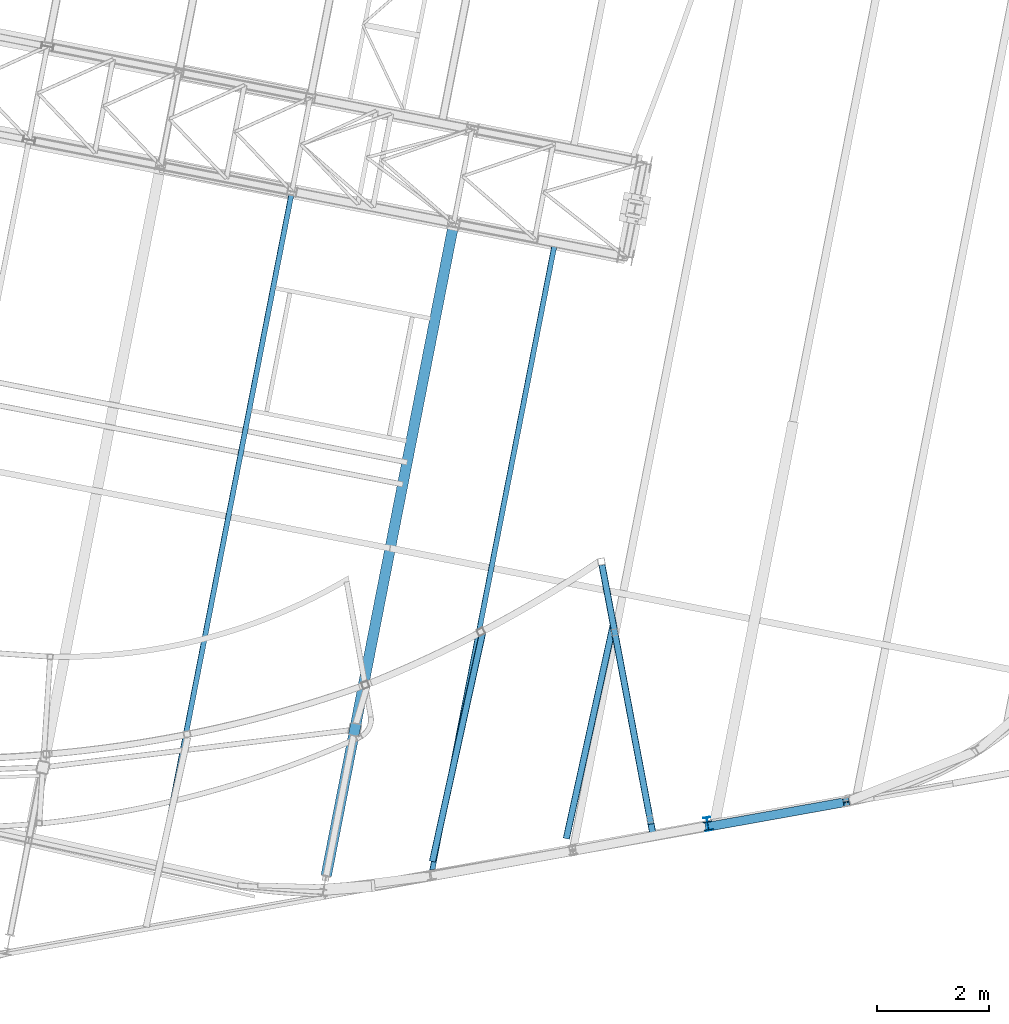
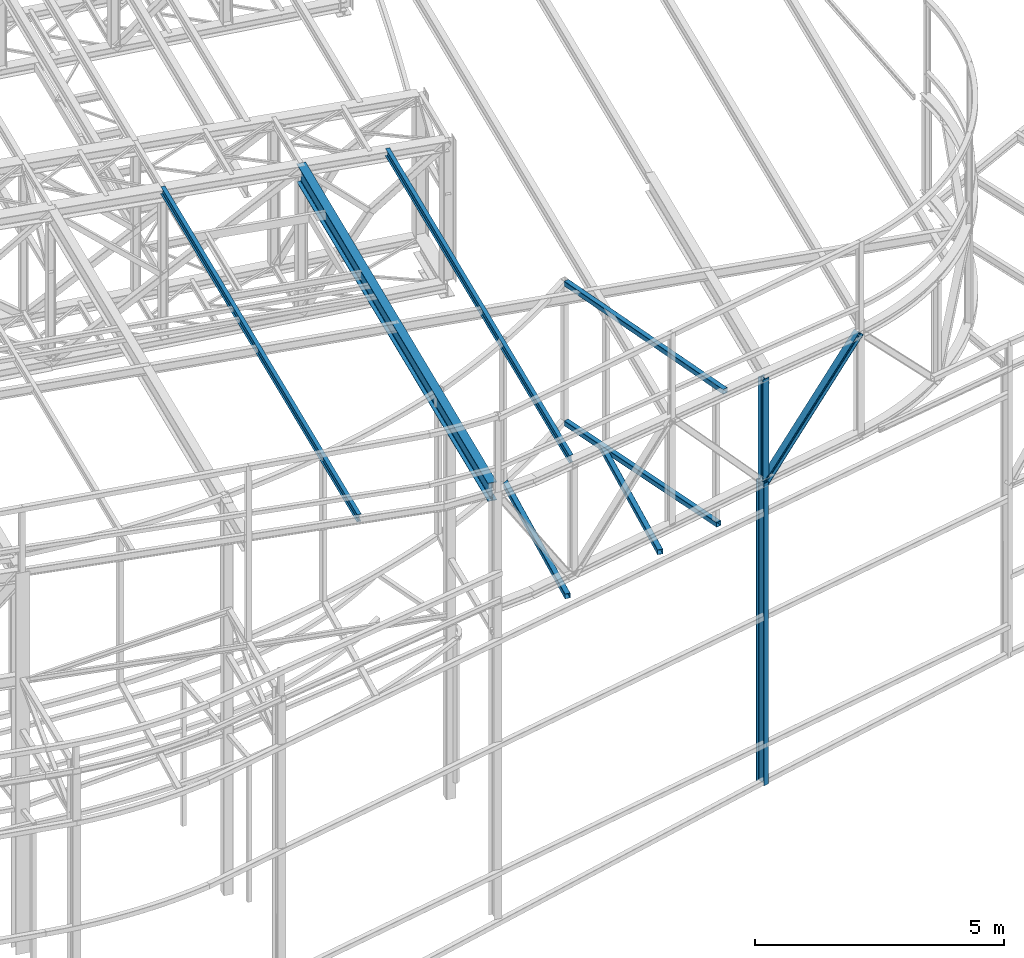
# One storey, part 57 of 215: 9 beams, 1 member, 10 elements without a shape of their own.
"""IFC2X3 building model written with IfcOpenShell, lengths in millimetres."""

from ifc_helpers import new_model, si_unit, frame, origin_with_axes, origin_2d_with_axis, place, context, subcontext, project, spatial, hollow_rectangle, i_section, extrude, clip, halfspace, material, type_object, element, aggregate, save


model = new_model("IFC2X3")

# Units and contexts
model_context = context("Model", 3, precision=1e-05, world=origin_with_axes())
body_context = subcontext(model_context, "Body", "Model", "MODEL_VIEW")
ifc_project = project(units=[si_unit("LENGTHUNIT", "METRE", prefix="MILLI"), si_unit("AREAUNIT", "SQUARE_METRE"), si_unit("VOLUMEUNIT", "CUBIC_METRE"), si_unit("MASSUNIT", "GRAM", prefix="KILO"), si_unit("TIMEUNIT", "SECOND"), si_unit("PLANEANGLEUNIT", "RADIAN"), si_unit("SOLIDANGLEUNIT", "STERADIAN"), si_unit("THERMODYNAMICTEMPERATUREUNIT", "DEGREE_CELSIUS"), si_unit("LUMINOUSINTENSITYUNIT", "LUMEN")], contexts=[model_context])

# Site, building, storey
site_placement = place(None, origin_with_axes())
site = spatial("IfcSite", under=ifc_project, at=site_placement, CompositionType="ELEMENT")
building_placement = place(site_placement, origin_with_axes())
building = spatial("IfcBuilding", under=site, at=building_placement, Name="Undefined", CompositionType="ELEMENT")
storey_placement = place(building_placement, origin_with_axes())
storey = spatial("IfcBuildingStorey", under=building, at=storey_placement, Name="Undefined", CompositionType="ELEMENT", Elevation=0.0)

# Assembly, beam
assembly_1_placement = place(storey_placement, origin_with_axes())
assembly_1 = element("IfcElementAssembly", 1, at=assembly_1_placement, inside=storey, Name="Steel Assembly", AssemblyPlace="NOTDEFINED", PredefinedType="RIGID_FRAME")
ifc_material = material(Name="STEEL/S275JR")
beam_type_1 = type_object("IfcBeamType", Name="IPE240", PredefinedType="NOTDEFINED")
beam_1_placement = place(assembly_1_placement, frame((91016.7687788865, 2951.99968971468, 9426.73715546441), z_axis=(-0.1771386489551, 0.98418590675053, -1.00000033828228e-09), x_axis=(0.0, 0.0, -1.0)))
beam_1 = element("IfcBeam", 2, at=beam_1_placement, type_object=beam_type_1, material=ifc_material, Name="MONTANT", ObjectType="IPE240", context=body_context, shape_type="Clipping", body=[
    clip(extrude(i_section(OverallWidth=120.0, OverallDepth=240.0, WebThickness=6.199999809, FlangeThickness=9.800000191, FilletRadius=15.0, at=origin_2d_with_axis()), frame((7423.4693885648, -1.45519152283669e-11, 0.0), z_axis=(-1.0, 0.0, 0.0), x_axis=(-6.93889390390723e-18, -1.0, -3.46944695195361e-18)), (0.0, 0.0, 1.0), 7423.5), halfspace(frame((7427.22859070963, 144.732145965143, -109.878690185373), z_axis=(-0.999000439160357, 0.0447003583089576, 2.29011865297713e-05), x_axis=(-1.00009037889739e-09, -0.000512348971731184, 0.999999868749257)), True)),
])
aggregate(assembly_1, [beam_1])

assembly_2_placement = place(storey_placement, origin_with_axes())
assembly_2 = element("IfcElementAssembly", 3, at=assembly_2_placement, inside=storey, Name="Steel Assembly", AssemblyPlace="NOTDEFINED", PredefinedType="RIGID_FRAME")
beam_type_2 = type_object("IfcBeamType", PredefinedType="NOTDEFINED")
beam_2_placement = place(assembly_2_placement, frame((89242.2107585349, 6095.02559260386, 8706.00013875785), z_axis=(0.976715475916409, -0.21453875898164, -1.00000033845017e-09), x_axis=(-0.214538758981639, -0.97671547591641, 0.0)))
beam_2 = element("IfcBeam", 4, at=beam_2_placement, type_object=beam_type_2, material=ifc_material, Name="LISSE", context=body_context, shape_type="Clipping", body=[
    clip(extrude(hollow_rectangle(XDim=120.0, YDim=120.0, WallThickness=5.0, InnerFilletRadius=5.0, OuterFilletRadius=10.0, at=origin_2d_with_axis()), frame((3486.87129744093, 1.81898940354586e-12, 9.67801199580878e-14), z_axis=(-1.0, 0.0, 0.0), x_axis=(-6.93889390390723e-18, -1.0, -3.46944695195361e-18)), (0.0, 0.0, 1.0), 3932.2), halfspace(frame((-226.451803865377, -59.999922311963, 16.6979386273451), z_axis=(0.392506577380147, -6.14406825347277e-09, -0.919749197723664), x_axis=(-6.93889390390723e-18, -1.0, -3.46944695195361e-18)), True)),
])
aggregate(assembly_2, [beam_2])

assembly_3_placement = place(storey_placement, origin_with_axes())
assembly_3 = element("IfcElementAssembly", 5, at=assembly_3_placement, inside=storey, Name="Steel Assembly", AssemblyPlace="NOTDEFINED", PredefinedType="RIGID_FRAME")
beam_3_placement = place(assembly_3_placement, frame((86972.7295310534, 6219.98047719203, 8706.00014167623), z_axis=(0.976715475916409, -0.21453875898164, -1.00000033845017e-09), x_axis=(-0.214538758981639, -0.97671547591641, 0.0)))
beam_3 = element("IfcBeam", 6, at=beam_3_placement, type_object=beam_type_2, material=ifc_material, Name="LISSE", context=body_context, shape_type="Clipping", body=[
    clip(extrude(hollow_rectangle(XDim=120.0, YDim=120.0, WallThickness=5.0, InnerFilletRadius=5.0, OuterFilletRadius=10.0, at=origin_2d_with_axis()), frame((4032.18191022412, 1.04229459450763e-22, 0.0), z_axis=(-1.0, 0.0, 0.0), x_axis=(-6.93889390390723e-18, -1.0, -3.46944695195361e-18)), (0.0, 0.0, 1.0), 4210.9), halfspace(frame((-145.120148966242, -59.9999350530652, 50.6813305532123), z_axis=(-0.771983742847682, -1.66052058476079e-09, -0.635642274222604), x_axis=(-6.93889390390723e-18, -1.0, -3.46944695195361e-18)), False)),
])
aggregate(assembly_3, [beam_3])

assembly_4_placement = place(storey_placement, origin_with_axes())
assembly_4 = element("IfcElementAssembly", 7, at=assembly_4_placement, inside=storey, Name="Steel Assembly", AssemblyPlace="NOTDEFINED", PredefinedType="RIGID_FRAME")
beam_4_placement = place(assembly_4_placement, frame((90005.0818830192, 2949.28661403261, 8706.00036403863), z_axis=(0.0, 0.0, -1.0), x_axis=(-0.186031417077286, 0.982543796408188, 3.29999998263352e-08)))
beam_4 = element("IfcBeam", 8, at=beam_4_placement, type_object=beam_type_2, material=ifc_material, Name="LISSE", context=body_context, shape_type="Clipping", body=[
    clip(extrude(hollow_rectangle(XDim=120.0, YDim=120.0, WallThickness=5.0, InnerFilletRadius=5.0, OuterFilletRadius=10.0, at=origin_2d_with_axis()), frame((4744.91866222964, -4.3446607691232e-14, -1.81898940354586e-12), z_axis=(-1.0, 0.0, 0.0), x_axis=(-6.93889390390723e-18, -1.0, -3.46944695195361e-18)), (0.0, 0.0, 1.0), 4744.9), halfspace(frame((4700.91971664662, 47.4391541010264, -59.9995418697345), z_axis=(-0.999410911530851, -0.0343195267023399, -3.25403953064898e-08), x_axis=(0.0, 0.0, -1.0)), True)),
])
aggregate(assembly_4, [beam_4])

assembly_5_placement = place(storey_placement, origin_with_axes())
assembly_5 = element("IfcElementAssembly", 9, at=assembly_5_placement, inside=storey, Name="Steel Assembly", AssemblyPlace="NOTDEFINED", PredefinedType="RIGID_FRAME")
beam_5_placement = place(assembly_5_placement, frame((90042.1218101927, 2753.50984265894, 12075.3447147273), z_axis=(-0.00277681399979952, 0.0119642699991486, -0.999924569928851), x_axis=(-0.186031387047881, 0.982467160252867, 0.0122720030031586)))
beam_5 = element("IfcBeam", 10, at=beam_5_placement, type_object=beam_type_2, material=ifc_material, Name="LISSE", context=body_context, shape_type="Clipping", body=[
    clip(extrude(hollow_rectangle(XDim=120.0, YDim=120.0, WallThickness=5.0, InnerFilletRadius=5.0, OuterFilletRadius=10.0, at=origin_2d_with_axis()), frame((4946.78277454329, -2.89897259805097e-11, -1.81898940354586e-12), z_axis=(-1.0, 0.0, 0.0), x_axis=(-6.93889390390723e-18, -1.0, -3.46944695195361e-18)), (0.0, 0.0, 1.0), 4946.8), halfspace(frame((4859.98125902296, 26.1246713751461, 3369.22737452108), z_axis=(-0.999335163660203, -0.0343399045514104, -0.0122475151616604), x_axis=(0.0122720022889183, -0.000502391758159023, -0.999924569936324)), True)),
])
aggregate(assembly_5, [beam_5])

assembly_6_placement = place(storey_placement, origin_with_axes())
assembly_6 = element("IfcElementAssembly", 11, at=assembly_6_placement, inside=storey, Name="Steel Assembly", AssemblyPlace="NOTDEFINED", PredefinedType="RIGID_FRAME")
beam_type_3 = type_object("IfcBeamType", Name="IPE180", PredefinedType="NOTDEFINED")
beam_6_placement = place(assembly_6_placement, frame((81268.7059178953, 2290.29895015508, 12311.5888996028), z_axis=(0.0304080349965938, -0.00594450399933318, 0.999519891888024), x_axis=(0.191859470081235, 0.981422408415534, 0.0)))
beam_6 = element("IfcBeam", 12, at=beam_6_placement, type_object=beam_type_3, material=ifc_material, ObjectType="IPE180", context=body_context, shape_type="SweptSolid", body=[
    extrude(i_section(OverallWidth=91.0, OverallDepth=180.0, WebThickness=5.300000191, FlangeThickness=8.0, FilletRadius=9.0, at=origin_2d_with_axis()), frame((12163.8734259709, 0.0, 1.05504783954211e-14), z_axis=(-1.0, 0.0, 0.0), x_axis=(-6.93889390390723e-18, -1.0, -3.46944695195361e-18)), (0.0, 0.0, 1.0), 12163.9),
])
aggregate(assembly_6, [beam_6])

assembly_7_placement = place(storey_placement, origin_with_axes())
assembly_7 = element("IfcElementAssembly", 13, at=assembly_7_placement, inside=storey, Name="Steel Assembly", AssemblyPlace="NOTDEFINED", PredefinedType="RIGID_FRAME")
beam_7_placement = place(assembly_7_placement, frame((86120.8980631865, 2213.2228025417, 12163.5139906248), z_axis=(0.0304080349965938, -0.00594450399933318, 0.999519891888024), x_axis=(0.191859470081235, 0.981422408415534, 0.0)))
beam_7 = element("IfcBeam", 14, at=beam_7_placement, type_object=beam_type_3, material=ifc_material, ObjectType="IPE180", context=body_context, shape_type="Clipping", body=[
    clip(extrude(i_section(OverallWidth=91.0, OverallDepth=180.0, WebThickness=5.300000191, FlangeThickness=8.0, FilletRadius=9.0, at=origin_2d_with_axis()), frame((11308.5791844053, -1.48657913530249e-11, -1.80918077465029e-12), z_axis=(-1.0, 0.0, 0.0), x_axis=(-6.93889390390723e-18, -1.0, -3.46944695195361e-18)), (0.0, 0.0, 1.0), 11422.6), halfspace(frame((-94.5316377379459, -331.102810911412, -12159.0929006566), z_axis=(0.932135442503494, 0.361935961367028, -0.0112194785146274), x_axis=(2.6746783987619e-10, -0.0309836363287614, -0.999519891888024)), True)),
])
aggregate(assembly_7, [beam_7])

assembly_8_placement = place(storey_placement, origin_with_axes())
assembly_8 = element("IfcElementAssembly", 15, at=assembly_8_placement, inside=storey, Name="Steel Assembly", AssemblyPlace="NOTDEFINED", PredefinedType="RIGID_FRAME")
beam_type_4 = type_object("IfcBeamType", Name="HEA160", PredefinedType="NOTDEFINED")
beam_8_placement = place(assembly_8_placement, frame((91022.9192927955, 2917.81292683802, 11976.2033968377), z_axis=(-0.177309416961143, 0.984155155784341, 0.0), x_axis=(0.0, 0.0, -1.0)))
beam_8 = element("IfcBeam", 16, at=beam_8_placement, type_object=beam_type_4, material=ifc_material, Name="MONTANT", ObjectType="HEA160", context=body_context, shape_type="SweptSolid", body=[
    extrude(i_section(OverallWidth=160.0, OverallDepth=152.0, WebThickness=6.0, FlangeThickness=9.0, FilletRadius=15.0, at=origin_2d_with_axis()), frame((2501.20507259342, 0.0, -3.63797880709171e-12), z_axis=(-1.0, 0.0, 0.0), x_axis=(-6.93889390390723e-18, -1.0, -3.46944695195361e-18)), (0.0, 0.0, 1.0), 2501.2),
])
aggregate(assembly_8, [beam_8])

# Assembly, member
assembly_9_placement = place(storey_placement, origin_with_axes())
assembly_9 = element("IfcElementAssembly", 17, at=assembly_9_placement, inside=storey, Name="Steel Assembly", AssemblyPlace="NOTDEFINED", PredefinedType="RIGID_FRAME")
member_type = type_object("IfcMemberType", Name="HEA160", PredefinedType="NOTDEFINED")
member_placement = place(assembly_9_placement, frame((93484.480129246, 3343.77087250193, 11968.0985028245), z_axis=(-0.704416702108423, -0.126327634019444, 0.698454321107503), x_axis=(-0.687486481900827, -0.123291428982215, -0.715654637896763)))
member = element("IfcMember", 18, at=member_placement, type_object=member_type, material=ifc_material, Name="LISSE", ObjectType="HEA160", context=body_context, shape_type="SweptSolid", body=[
    extrude(i_section(OverallWidth=160.0, OverallDepth=152.0, WebThickness=6.0, FlangeThickness=9.0, FilletRadius=15.0, at=origin_2d_with_axis()), frame((3576.59043601194, 1.69571527133519e-12, -6.68033565642624e-12), z_axis=(-1.0, 0.0, 0.0), x_axis=(-6.93889390390723e-18, -1.0, -3.46944695195361e-18)), (0.0, 0.0, 1.0), 3576.6),
])
aggregate(assembly_9, [member])

# Assembly, beam
assembly_10_placement = place(storey_placement, origin_with_axes())
assembly_10 = element("IfcElementAssembly", 19, at=assembly_10_placement, inside=storey, Name="Steel Assembly", AssemblyPlace="NOTDEFINED", PredefinedType="RIGID_FRAME")
beam_type_5 = type_object("IfcBeamType", Name="IPE450", PredefinedType="NOTDEFINED")
beam_9_placement = place(assembly_10_placement, frame((86489.0268442405, 13663.8953451647, 12083.264477371), z_axis=(0.0, 0.0, 1.0), x_axis=(-0.191859508000518, -0.981422401002646, -1.00000033853845e-09)))
beam_9 = element("IfcBeam", 20, at=beam_9_placement, type_object=beam_type_5, material=ifc_material, Name="POUTRE", ObjectType="IPE450", context=body_context, shape_type="SweptSolid", body=[
    extrude(i_section(OverallWidth=190.0, OverallDepth=450.0, WebThickness=9.399999619, FlangeThickness=14.60000038, FilletRadius=21.0, at=origin_2d_with_axis()), frame((11852.9517003382, 1.48831748269027e-11, -1.81898940599699e-12), z_axis=(-1.0, 0.0, 0.0), x_axis=(-6.93889390390723e-18, -1.0, -3.46944695195361e-18)), (0.0, 0.0, 1.0), 11853.0),
])
aggregate(assembly_10, [beam_9])

save(model, "model.ifc")
